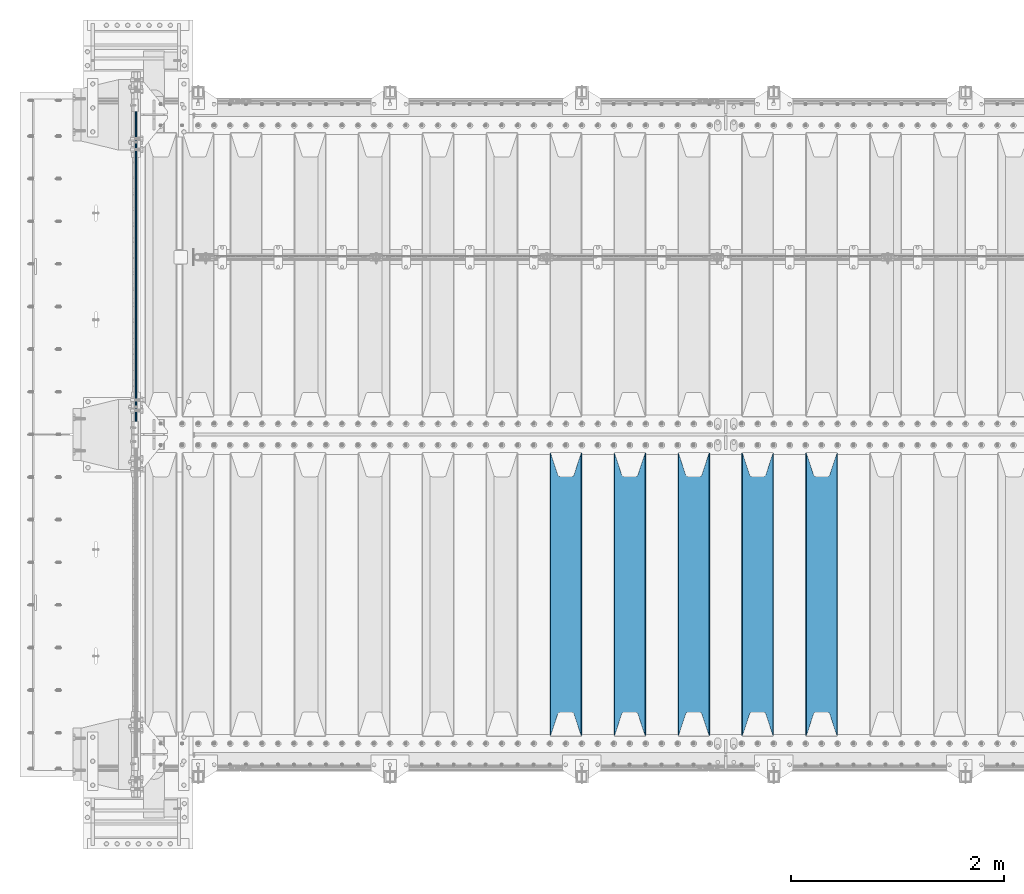
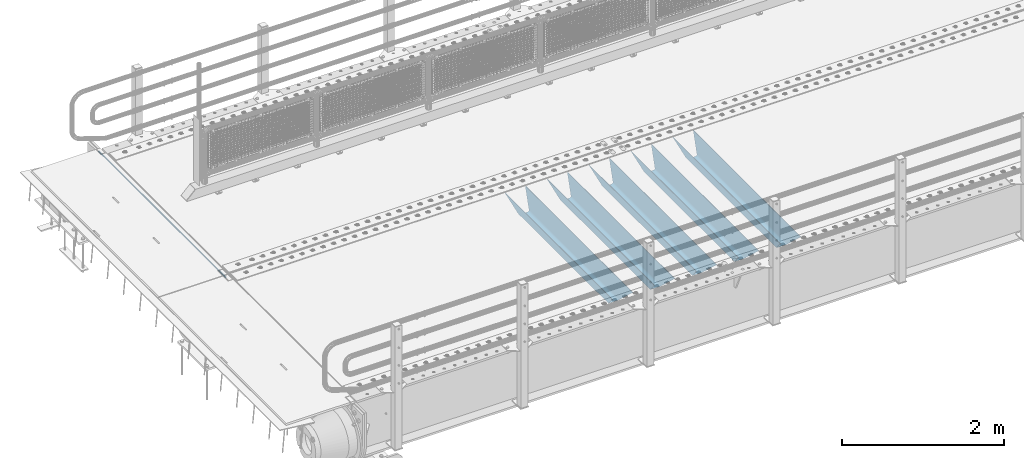
# One storey, part 92 of 208: 6 beams.
"""IFC2X3 building model written with IfcOpenShell, lengths in millimetres."""

import ifcopenshell
import ifcopenshell.guid

model = None  # the IFC model being written
_history = None  # IfcOwnerHistory: only IFC2X3 demands one
_inside = {}  # id of a spatial element -> (the spatial element, [elements in it])
_under = {}  # id of a project, library or spatial element -> (it, [spatial elements below it])
_declared = {}  # id of a project -> (the project, [libraries it declares])
_typed = {}  # id of a type object -> (the type object, [elements of that type])
_made_of = {}  # id of a material, layer set ... -> (it, [elements and type objects made of it])


def new_model(schema):
    """Start an empty IFC model of exactly this schema.

    Asked for "IFC4X3", IfcOpenShell would pick the latest addendum, in which some entities
    have other attributes; the version numbers below select the first issue.
    IFC2X3 requires an IfcOwnerHistory on every rooted entity: one is made here for all.
    """
    global model, _history
    if schema == "IFC4X3":
        model = ifcopenshell.file(schema_version=(4, 3, 0, 0))
    else:
        model = ifcopenshell.file(schema=schema)
    _inside.clear()
    _under.clear()
    _declared.clear()
    _typed.clear()
    _made_of.clear()
    _history = None
    if model.schema == "IFC2X3":
        org = make("IfcOrganization", Name="unknown")
        user = make(
            "IfcPersonAndOrganization",
            ThePerson=make("IfcPerson", FamilyName="unknown"),
            TheOrganization=org,
        )
        app = make(
            "IfcApplication",
            ApplicationDeveloper=org,
            Version="unknown",
            ApplicationFullName="unknown",
            ApplicationIdentifier="unknown",
        )
        _history = make(
            "IfcOwnerHistory",
            OwningUser=user,
            OwningApplication=app,
            ChangeAction="ADDED",
            CreationDate=0,
        )
    return model


def make(cls, **values):
    """One entity of the class cls with the attributes given. An attribute that is None is left unset."""
    return model.create_entity(
        cls, **{name: value for name, value in values.items() if value is not None}
    )


def rooted(cls, **values):
    """An entity with a GlobalId (a new one), such as an element, a storey or a relation."""
    return make(cls, GlobalId=ifcopenshell.guid.new(), OwnerHistory=_history, **values)


def si_unit(unit_type, name, prefix=None):
    """IfcSIUnit, for example si_unit("LENGTHUNIT", "METRE", prefix="MILLI")."""
    return make("IfcSIUnit", UnitType=unit_type, Prefix=prefix, Name=name)


def assignment(units):
    """IfcUnitAssignment: the units of a project."""
    return None if units is None else make("IfcUnitAssignment", Units=units)


def point(xyz):
    """IfcCartesianPoint."""
    return None if xyz is None else make("IfcCartesianPoint", Coordinates=xyz)


def direction(xyz):
    """IfcDirection."""
    return None if xyz is None else make("IfcDirection", DirectionRatios=xyz)


def frame(location, z_axis=None, x_axis=None):
    """IfcAxis2Placement3D, a coordinate frame: its origin and axes. An axis left out is left unset."""
    return make(
        "IfcAxis2Placement3D",
        Location=point(location),
        Axis=direction(z_axis),
        RefDirection=direction(x_axis),
    )


def origin_with_axes():
    """The frame at (0, 0, 0) with the z axis (0, 0, 1) and the x axis (1, 0, 0) written out."""
    return frame((0.0, 0.0, 0.0), z_axis=(0.0, 0.0, 1.0), x_axis=(1.0, 0.0, 0.0))


def place(relative_to, where):
    """IfcLocalPlacement: puts the frame where relative to a parent placement (None: the world)."""
    return make(
        "IfcLocalPlacement", PlacementRelTo=relative_to, RelativePlacement=where
    )


def context(
    kind, dimensions, precision=None, world=None, true_north=None, identifier=None
):
    """IfcGeometricRepresentationContext, for example the 3D "Model" context."""
    return make(
        "IfcGeometricRepresentationContext",
        ContextIdentifier=identifier,
        ContextType=kind,
        CoordinateSpaceDimension=dimensions,
        Precision=precision,
        WorldCoordinateSystem=world,
        TrueNorth=true_north,
    )


def subcontext(parent, identifier, kind, view, scale=None):
    """IfcGeometricRepresentationSubContext, for example "Body" below "Model"."""
    return make(
        "IfcGeometricRepresentationSubContext",
        ContextIdentifier=identifier,
        ContextType=kind,
        ParentContext=parent,
        TargetScale=scale,
        TargetView=view,
    )


def project(units=None, contexts=None):
    """IfcProject with its units and contexts."""
    return rooted(
        "IfcProject",
        Name="project",
        RepresentationContexts=contexts,
        UnitsInContext=assignment(units),
    )


def spatial(cls, under=None, at=None, **own):
    """A site, building, storey or space (cls), placed at a placement, below another one or the project."""
    s = rooted(cls, ObjectPlacement=at, **own)
    if under is not None:
        _under.setdefault(under.id(), (under, []))[1].append(s)
    return s


def faces_of(points, faces, orient=None, outer=None):
    """IfcFace entities. A face is a list of loops; a loop is a list of indices into points, from 0.

    orient and outer hold one flag for each loop. By default every Orientation is true, the
    first loop of a face is its IfcFaceOuterBound and the others are IfcFaceBound.
    """
    made = []
    for i, loops in enumerate(faces):
        bounds = []
        for j, loop in enumerate(loops):
            is_outer = j == 0 if outer is None else outer[i][j]
            bounds.append(
                make(
                    "IfcFaceOuterBound" if is_outer else "IfcFaceBound",
                    Bound=make("IfcPolyLoop", Polygon=[points[k] for k in loop]),
                    Orientation=True if orient is None else orient[i][j],
                )
            )
        made.append(make("IfcFace", Bounds=bounds))
    return made


def faceted_brep(points, faces, orient=None, outer=None, voids=None):
    """IfcFacetedBrep: a solid bounded by flat faces; with voids (closed shells), ...WithVoids."""
    shared = [point(p) for p in points]
    hull = make("IfcClosedShell", CfsFaces=faces_of(shared, faces, orient, outer))
    if voids is None:
        return make("IfcFacetedBrep", Outer=hull)
    return make(
        "IfcFacetedBrepWithVoids",
        Outer=hull,
        Voids=[
            make(cls, CfsFaces=faces_of(shared, fs, o, b)) for cls, fs, o, b in voids
        ],
    )


def shape(context_of_items, identifier, shape_type, items):
    """IfcShapeRepresentation: the items that make up one representation, for example the "Body"."""
    return make(
        "IfcShapeRepresentation",
        ContextOfItems=context_of_items,
        RepresentationIdentifier=identifier,
        RepresentationType=shape_type,
        Items=items,
    )


def material(Name=None, Category=None):
    """IfcMaterial."""
    return make("IfcMaterial", Name=Name, Category=Category)


def made_of(thing, what):
    """Note that an element or type object is made of a material, layer set ...; save() writes the relation."""
    if what is not None:
        _made_of.setdefault(what.id(), (what, []))[1].append(thing)
    return thing


def type_object(cls, material=None, **own):
    """A type object (cls), such as IfcWallType, which elements share."""
    return made_of(rooted(cls, **own), material)


def element(
    cls,
    number,
    at=None,
    inside=None,
    cuts=None,
    type_object=None,
    material=None,
    context=None,
    identifier="Body",
    shape_type=None,
    held_by="IfcProductDefinitionShape",
    body=None,
    shapes=None,
    **own,
):
    """One element of the class cls, such as IfcWall. Its Tag is "e" and its number.

    at: its placement. inside: the storey or other place that contains it. cuts: it is an
    opening in that element (IfcRelVoidsElement). A single representation is given by context,
    identifier, shape_type and body (its items); several are given by shapes. held_by: the class
    of the entity that holds the representations. save() writes the other relations.
    """
    e = rooted(cls, Tag="e%d" % number, ObjectPlacement=at, **own)
    if body is not None:
        shapes = [shape(context, identifier, shape_type, body)]
    if shapes is not None:
        e.Representation = make(held_by, Representations=shapes)
    if inside is not None:
        _inside.setdefault(inside.id(), (inside, []))[1].append(e)
    if cuts is not None:
        rooted(
            "IfcRelVoidsElement", RelatingBuildingElement=cuts, RelatedOpeningElement=e
        )
    if type_object is not None:
        _typed.setdefault(type_object.id(), (type_object, []))[1].append(e)
    return made_of(e, material)


def aggregate(whole, parts):
    """IfcRelAggregates: a whole, such as a stair, and the parts it consists of."""
    return rooted("IfcRelAggregates", RelatingObject=whole, RelatedObjects=parts)


def save(model, path):
    """Write the relations noted so far, then the file.

    IfcRelAggregates (storeys below a building ...), IfcRelContainedInSpatialStructure (elements
    in a storey), IfcRelDefinesByType, IfcRelAssociatesMaterial and IfcRelDeclares: one each for
    every whole, place, type object, material and project.
    """
    for whole, parts in _under.values():
        aggregate(whole, parts)
    for where, things in _inside.values():
        rooted(
            "IfcRelContainedInSpatialStructure",
            RelatedElements=things,
            RelatingStructure=where,
        )
    for kind, things in _typed.values():
        rooted("IfcRelDefinesByType", RelatedObjects=things, RelatingType=kind)
    for what, things in _made_of.values():
        rooted("IfcRelAssociatesMaterial", RelatedObjects=things, RelatingMaterial=what)
    for by, libraries in _declared.values():
        rooted("IfcRelDeclares", RelatingContext=by, RelatedDefinitions=libraries)
    model.write(path)


model = new_model("IFC2X3")

# Units and contexts
model_context = context("Model", 3, precision=1e-05, world=origin_with_axes())
body_context = subcontext(model_context, "Body", "Model", "MODEL_VIEW")
ifc_project = project(units=[si_unit("LENGTHUNIT", "METRE", prefix="MILLI"), si_unit("AREAUNIT", "SQUARE_METRE"), si_unit("VOLUMEUNIT", "CUBIC_METRE"), si_unit("MASSUNIT", "GRAM", prefix="KILO"), si_unit("TIMEUNIT", "SECOND"), si_unit("PLANEANGLEUNIT", "RADIAN"), si_unit("SOLIDANGLEUNIT", "STERADIAN"), si_unit("THERMODYNAMICTEMPERATUREUNIT", "DEGREE_CELSIUS"), si_unit("LUMINOUSINTENSITYUNIT", "LUMEN")], contexts=[model_context])

# Site, building, storey
site_placement = place(None, origin_with_axes())
site = spatial("IfcSite", under=ifc_project, at=site_placement, CompositionType="ELEMENT")
building_placement = place(site_placement, origin_with_axes())
building = spatial("IfcBuilding", under=site, at=building_placement, Name="Standard", CompositionType="ELEMENT")
storey_placement = place(building_placement, origin_with_axes())
storey = spatial("IfcBuildingStorey", under=building, at=storey_placement, Name="Undefined", CompositionType="ELEMENT", Elevation=0.0)

# Beams
ifc_material = material(Name="STEEL/S355N")
beam_type_1 = type_object("IfcBeamType", Name="D20", PredefinedType="NOTDEFINED")
beam_1_placement = place(storey_placement, frame((-42485.0, 3005.0, -25.9999999971316), z_axis=(0.0, 0.0, 1.0), x_axis=(0.0, 1.0, 0.0)))
element("IfcBeam", 1, at=beam_1_placement, inside=storey, type_object=beam_type_1, material=ifc_material, ObjectType="D20", context=body_context, shape_type="Brep", body=[
    faceted_brep([(0.0, -10.0, 0.0), (0.0, -7.07106781186303, -7.07106781186548), (3145.0, -7.07106781186303, -7.07106781186548), (3145.0, -10.0, 0.0), (0.0, 0.0, -10.0), (3145.0, 0.0, -10.0), (0.0, 7.07106781186303, -7.07106781186547), (3145.0, 7.07106781186303, -7.07106781186547), (0.0, 10.0, 0.0), (3145.0, 10.0, 0.0), (0.0, 7.07106781186303, 7.07106781186548), (3145.0, 7.07106781186303, 7.07106781186548), (0.0, 0.0, 10.0), (3145.0, 0.0, 10.0), (0.0, -7.07106781186303, 7.07106781186548), (3145.0, -7.07106781186303, 7.07106781186548)], [[[0, 1, 2, 3]], [[1, 4, 5, 2]], [[4, 6, 7, 5]], [[6, 8, 9, 7]], [[8, 10, 11, 9]], [[10, 12, 13, 11]], [[12, 14, 15, 13]], [[14, 0, 3, 15]], [[5, 7, 9, 11, 13, 15, 3, 2]], [[14, 12, 10, 8, 6, 4, 1, 0]]]),
])
beam_type_2 = type_object("IfcBeamType", PredefinedType="NOTDEFINED")
beam_2_placement = place(storey_placement, frame((-36050.0, 175.0, -115.0), z_axis=(0.0, 0.0, 1.0), x_axis=(0.0, 1.0, 0.0)))
element("IfcBeam", 2, at=beam_2_placement, inside=storey, type_object=beam_type_2, material=ifc_material, context=body_context, shape_type="Brep", body=[
    faceted_brep([(0.0, 150.0, 115.0), (0.0, 143.689999999999, 115.0), (2650.00000000297, 143.689999999999, 115.0), (2650.00000000297, 150.0, 115.0), (2650.00000000297, 142.059565218402, 110.0000000031), (2650.00000000297, 148.369565218403, 110.0000000031), (2441.90079219208, -80.1103600731112, -98.0992078077845), (2437.7588105432, -77.5672621345584, -102.241189456673), (2434.06523489746, -74.4080125315522, -105.934765102404), (2430.91086095089, -70.710272125576, -109.089139048974), (2428.37322971128, -66.5649389910068, -111.626770288588), (2426.51472138055, -62.0739139532889, -113.485278619323), (2425.38102192091, -57.3475956567672, -114.618978078955), (2424.99999999987, -52.5021667386536, -115.0), (2424.99999999987, 52.5021667386536, -115.0), (2425.38102192091, 57.3475956567672, -114.618978078955), (2426.51472138055, 62.0739139532889, -113.485278619323), (2428.37322971128, 66.5649389910068, -111.626770288588), (2430.91086095089, 70.710272125576, -109.089139048974), (2434.06523489746, 74.4080125315522, -105.934765102404), (2437.7588105432, 77.5672621345584, -102.241189456673), (2441.90079219208, 80.1103600731112, -98.0992078077846), (2446.38936140511, 81.9747917625791, -93.6106385947584), (2448.24948500409, 76.2713538057251, -91.7505149957729), (2444.62967112262, 74.76777986261, -95.3703288772456), (2441.28936334126, 72.7168944282894, -98.710636658607), (2438.31067330438, 70.1691124903846, -101.689326695487), (2435.76682334747, 67.1870637758839, -104.233176652398), (2433.72034654133, 63.8440531834895, -106.279653458539), (2432.22154950041, 60.222258798236, -107.778450499454), (2431.30727574265, 56.4107117849089, -108.692724257221), (2430.99999999987, 52.5031078186876, -109.0), (2430.99999999987, -52.5031078186876, -109.0), (2431.30727574265, -56.4107117849089, -108.692724257221), (2432.22154950041, -60.222258798236, -107.778450499454), (2433.72034654133, -63.8440531834895, -106.279653458539), (2435.76682334747, -67.1870637758839, -104.233176652398), (2438.31067330438, -70.1691124903846, -101.689326695487), (2441.28936334126, -72.7168944282894, -98.7106366586071), (2444.62967112262, -74.76777986261, -95.3703288772457), (2448.24948500409, -76.2713538057251, -91.7505149957729), (2650.00000000297, -142.059565218402, 110.0000000031), (2650.00000000297, -148.369565218403, 110.0000000031), (2446.38936140511, -81.9747917625791, -93.6106385947584), (2650.00000000297, -143.689999999999, 115.0), (2650.00000000297, -150.0, 115.0), (0.0, -143.689999999999, 115.0), (0.0, -150.0, 115.0), (0.0, -148.369565218261, 110.000000002663), (203.610638597421, -81.9747917625791, -93.6106385947584), (208.099207810448, -80.1103600731112, -98.0992078077845), (212.241189459336, -77.5672621345584, -102.241189456673), (215.934765105067, -74.4080125315522, -105.934765102404), (219.089139051637, -70.710272125576, -109.089139048974), (221.626770291251, -66.5649389910068, -111.626770288588), (223.485278621986, -62.0739139532889, -113.485278619323), (224.618978081618, -57.3475956567672, -114.618978078955), (225.000000002663, -52.5021667386536, -115.0), (225.000000002663, 52.5021667386536, -115.0), (224.618978081618, 57.3475956567672, -114.618978078955), (223.485278621986, 62.0739139532889, -113.485278619323), (221.626770291251, 66.5649389910068, -111.626770288588), (219.089139051637, 70.710272125576, -109.089139048974), (215.934765105067, 74.4080125315522, -105.934765102404), (212.241189459336, 77.5672621345584, -102.241189456673), (208.099207810448, 80.1103600731112, -98.0992078077846), (203.610638597421, 81.9747917625791, -93.6106385947584), (0.0, 148.369565218261, 110.000000002663), (0.0, 142.05956521826, 110.000000002663), (201.750514998436, 76.2713538057251, -91.7505149957729), (205.370328879908, 74.76777986261, -95.3703288772456), (208.71063666127, 72.7168944282894, -98.710636658607), (211.68932669815, 70.1691124903846, -101.689326695487), (214.233176655061, 67.1870637758839, -104.233176652398), (216.279653461202, 63.8440531834895, -106.279653458539), (217.778450502116, 60.222258798236, -107.778450499454), (218.692724259884, 56.4107117849089, -108.692724257221), (219.000000002663, 52.5031078186876, -109.0), (219.000000002663, -52.5031078186876, -109.0), (218.692724259884, -56.4107117849089, -108.692724257221), (217.778450502116, -60.222258798236, -107.778450499454), (216.279653461202, -63.8440531834895, -106.279653458539), (214.233176655061, -67.1870637758839, -104.233176652398), (211.68932669815, -70.1691124903846, -101.689326695487), (208.71063666127, -72.7168944282894, -98.7106366586071), (205.370328879908, -74.76777986261, -95.3703288772457), (201.750514998436, -76.2713538057251, -91.7505149957729), (0.0, -142.05956521826, 110.000000002663)], [[[0, 1, 2, 3]], [[3, 2, 4, 5]], [[6, 7, 8, 9, 10, 11, 12, 13, 14, 15, 16, 17, 18, 19, 20, 21, 22, 5, 4, 23, 24, 25, 26, 27, 28, 29, 30, 31, 32, 33, 34, 35, 36, 37, 38, 39, 40, 41, 42, 43]], [[44, 45, 42, 41]], [[46, 47, 45, 44]], [[43, 42, 45, 47, 48, 49]], [[6, 43, 49, 50]], [[7, 6, 50, 51]], [[8, 7, 51, 52]], [[9, 8, 52, 53]], [[10, 9, 53, 54]], [[11, 10, 54, 55]], [[12, 11, 55, 56]], [[13, 12, 56, 57]], [[14, 13, 57, 58]], [[15, 14, 58, 59]], [[16, 15, 59, 60]], [[17, 16, 60, 61]], [[18, 17, 61, 62]], [[19, 18, 62, 63]], [[20, 19, 63, 64]], [[21, 20, 64, 65]], [[22, 21, 65, 66]], [[0, 3, 5, 22, 66, 67]], [[1, 0, 67, 68]], [[23, 4, 2, 1, 68, 69]], [[24, 23, 69, 70]], [[25, 24, 70, 71]], [[26, 25, 71, 72]], [[27, 26, 72, 73]], [[28, 27, 73, 74]], [[29, 28, 74, 75]], [[30, 29, 75, 76]], [[31, 30, 76, 77]], [[32, 31, 77, 78]], [[33, 32, 78, 79]], [[34, 33, 79, 80]], [[35, 34, 80, 81]], [[36, 35, 81, 82]], [[37, 36, 82, 83]], [[38, 37, 83, 84]], [[39, 38, 84, 85]], [[40, 39, 85, 86]], [[46, 44, 41, 40, 86, 87]], [[47, 46, 87, 48]], [[86, 85, 84, 83, 82, 81, 80, 79, 78, 77, 76, 75, 74, 73, 72, 71, 70, 69, 68, 67, 66, 65, 64, 63, 62, 61, 60, 59, 58, 57, 56, 55, 54, 53, 52, 51, 50, 49, 48, 87]]]),
])
beam_3_placement = place(storey_placement, frame((-36650.0, 175.0, -115.0), z_axis=(0.0, 0.0, 1.0), x_axis=(0.0, 1.0, 0.0)))
element("IfcBeam", 3, at=beam_3_placement, inside=storey, type_object=beam_type_2, material=ifc_material, context=body_context, shape_type="Brep", body=[
    faceted_brep([(0.0, 150.0, 115.0), (0.0, 143.689999999999, 115.0), (2650.00000000297, 143.689999999999, 115.0), (2650.00000000297, 150.0, 115.0), (2650.00000000297, 142.059565218402, 110.0000000031), (2650.00000000297, 148.369565218403, 110.0000000031), (2441.90079219208, -80.1103600731112, -98.0992078077845), (2437.7588105432, -77.5672621345584, -102.241189456673), (2434.06523489746, -74.4080125315522, -105.934765102404), (2430.91086095089, -70.710272125576, -109.089139048974), (2428.37322971128, -66.5649389910068, -111.626770288588), (2426.51472138055, -62.0739139532889, -113.485278619323), (2425.38102192091, -57.3475956567672, -114.618978078955), (2424.99999999987, -52.5021667386536, -115.0), (2424.99999999987, 52.5021667386536, -115.0), (2425.38102192091, 57.3475956567672, -114.618978078955), (2426.51472138055, 62.0739139532889, -113.485278619323), (2428.37322971128, 66.5649389910068, -111.626770288588), (2430.91086095089, 70.710272125576, -109.089139048974), (2434.06523489746, 74.4080125315522, -105.934765102404), (2437.7588105432, 77.5672621345584, -102.241189456673), (2441.90079219208, 80.1103600731112, -98.0992078077846), (2446.38936140511, 81.9747917625791, -93.6106385947584), (2448.24948500409, 76.2713538057251, -91.7505149957729), (2444.62967112262, 74.76777986261, -95.3703288772456), (2441.28936334126, 72.7168944282894, -98.710636658607), (2438.31067330438, 70.1691124903846, -101.689326695487), (2435.76682334747, 67.1870637758839, -104.233176652398), (2433.72034654133, 63.8440531834895, -106.279653458539), (2432.22154950041, 60.222258798236, -107.778450499454), (2431.30727574265, 56.4107117849089, -108.692724257221), (2430.99999999987, 52.5031078186876, -109.0), (2430.99999999987, -52.5031078186876, -109.0), (2431.30727574265, -56.4107117849089, -108.692724257221), (2432.22154950041, -60.222258798236, -107.778450499454), (2433.72034654133, -63.8440531834895, -106.279653458539), (2435.76682334747, -67.1870637758839, -104.233176652398), (2438.31067330438, -70.1691124903846, -101.689326695487), (2441.28936334126, -72.7168944282894, -98.7106366586071), (2444.62967112262, -74.76777986261, -95.3703288772457), (2448.24948500409, -76.2713538057251, -91.7505149957729), (2650.00000000297, -142.059565218402, 110.0000000031), (2650.00000000297, -148.369565218403, 110.0000000031), (2446.38936140511, -81.9747917625791, -93.6106385947584), (2650.00000000297, -143.689999999999, 115.0), (2650.00000000297, -150.0, 115.0), (0.0, -143.689999999999, 115.0), (0.0, -150.0, 115.0), (0.0, -148.369565218261, 110.000000002663), (203.610638597421, -81.9747917625791, -93.6106385947584), (208.099207810448, -80.1103600731112, -98.0992078077845), (212.241189459336, -77.5672621345584, -102.241189456673), (215.934765105067, -74.4080125315522, -105.934765102404), (219.089139051637, -70.710272125576, -109.089139048974), (221.626770291251, -66.5649389910068, -111.626770288588), (223.485278621986, -62.0739139532889, -113.485278619323), (224.618978081618, -57.3475956567672, -114.618978078955), (225.000000002663, -52.5021667386536, -115.0), (225.000000002663, 52.5021667386536, -115.0), (224.618978081618, 57.3475956567672, -114.618978078955), (223.485278621986, 62.0739139532889, -113.485278619323), (221.626770291251, 66.5649389910068, -111.626770288588), (219.089139051637, 70.710272125576, -109.089139048974), (215.934765105067, 74.4080125315522, -105.934765102404), (212.241189459336, 77.5672621345584, -102.241189456673), (208.099207810448, 80.1103600731112, -98.0992078077846), (203.610638597421, 81.9747917625791, -93.6106385947584), (0.0, 148.369565218261, 110.000000002663), (0.0, 142.05956521826, 110.000000002663), (201.750514998436, 76.2713538057251, -91.7505149957729), (205.370328879908, 74.76777986261, -95.3703288772456), (208.71063666127, 72.7168944282894, -98.710636658607), (211.68932669815, 70.1691124903846, -101.689326695487), (214.233176655061, 67.1870637758839, -104.233176652398), (216.279653461202, 63.8440531834895, -106.279653458539), (217.778450502116, 60.222258798236, -107.778450499454), (218.692724259884, 56.4107117849089, -108.692724257221), (219.000000002663, 52.5031078186876, -109.0), (219.000000002663, -52.5031078186876, -109.0), (218.692724259884, -56.4107117849089, -108.692724257221), (217.778450502116, -60.222258798236, -107.778450499454), (216.279653461202, -63.8440531834895, -106.279653458539), (214.233176655061, -67.1870637758839, -104.233176652398), (211.68932669815, -70.1691124903846, -101.689326695487), (208.71063666127, -72.7168944282894, -98.7106366586071), (205.370328879908, -74.76777986261, -95.3703288772457), (201.750514998436, -76.2713538057251, -91.7505149957729), (0.0, -142.05956521826, 110.000000002663)], [[[0, 1, 2, 3]], [[3, 2, 4, 5]], [[6, 7, 8, 9, 10, 11, 12, 13, 14, 15, 16, 17, 18, 19, 20, 21, 22, 5, 4, 23, 24, 25, 26, 27, 28, 29, 30, 31, 32, 33, 34, 35, 36, 37, 38, 39, 40, 41, 42, 43]], [[44, 45, 42, 41]], [[46, 47, 45, 44]], [[43, 42, 45, 47, 48, 49]], [[6, 43, 49, 50]], [[7, 6, 50, 51]], [[8, 7, 51, 52]], [[9, 8, 52, 53]], [[10, 9, 53, 54]], [[11, 10, 54, 55]], [[12, 11, 55, 56]], [[13, 12, 56, 57]], [[14, 13, 57, 58]], [[15, 14, 58, 59]], [[16, 15, 59, 60]], [[17, 16, 60, 61]], [[18, 17, 61, 62]], [[19, 18, 62, 63]], [[20, 19, 63, 64]], [[21, 20, 64, 65]], [[22, 21, 65, 66]], [[0, 3, 5, 22, 66, 67]], [[1, 0, 67, 68]], [[23, 4, 2, 1, 68, 69]], [[24, 23, 69, 70]], [[25, 24, 70, 71]], [[26, 25, 71, 72]], [[27, 26, 72, 73]], [[28, 27, 73, 74]], [[29, 28, 74, 75]], [[30, 29, 75, 76]], [[31, 30, 76, 77]], [[32, 31, 77, 78]], [[33, 32, 78, 79]], [[34, 33, 79, 80]], [[35, 34, 80, 81]], [[36, 35, 81, 82]], [[37, 36, 82, 83]], [[38, 37, 83, 84]], [[39, 38, 84, 85]], [[40, 39, 85, 86]], [[46, 44, 41, 40, 86, 87]], [[47, 46, 87, 48]], [[86, 85, 84, 83, 82, 81, 80, 79, 78, 77, 76, 75, 74, 73, 72, 71, 70, 69, 68, 67, 66, 65, 64, 63, 62, 61, 60, 59, 58, 57, 56, 55, 54, 53, 52, 51, 50, 49, 48, 87]]]),
])
beam_4_placement = place(storey_placement, frame((-37250.0, 175.0, -115.0), z_axis=(0.0, 0.0, 1.0), x_axis=(0.0, 1.0, 0.0)))
element("IfcBeam", 4, at=beam_4_placement, inside=storey, type_object=beam_type_2, material=ifc_material, context=body_context, shape_type="Brep", body=[
    faceted_brep([(0.0, 150.0, 115.0), (0.0, 143.689999999999, 115.0), (2650.00000000297, 143.689999999999, 115.0), (2650.00000000297, 150.0, 115.0), (2650.00000000297, 142.059565218402, 110.0000000031), (2650.00000000297, 148.369565218403, 110.0000000031), (2441.90079219208, -80.1103600731112, -98.0992078077845), (2437.7588105432, -77.5672621345584, -102.241189456673), (2434.06523489746, -74.4080125315522, -105.934765102404), (2430.91086095089, -70.710272125576, -109.089139048974), (2428.37322971128, -66.5649389910068, -111.626770288588), (2426.51472138055, -62.0739139532889, -113.485278619323), (2425.38102192091, -57.3475956567672, -114.618978078955), (2424.99999999987, -52.5021667386536, -115.0), (2424.99999999987, 52.5021667386536, -115.0), (2425.38102192091, 57.3475956567672, -114.618978078955), (2426.51472138055, 62.0739139532889, -113.485278619323), (2428.37322971128, 66.5649389910068, -111.626770288588), (2430.91086095089, 70.710272125576, -109.089139048974), (2434.06523489746, 74.4080125315522, -105.934765102404), (2437.7588105432, 77.5672621345584, -102.241189456673), (2441.90079219208, 80.1103600731112, -98.0992078077846), (2446.38936140511, 81.9747917625791, -93.6106385947584), (2448.24948500409, 76.2713538057251, -91.7505149957729), (2444.62967112262, 74.76777986261, -95.3703288772456), (2441.28936334126, 72.7168944282894, -98.710636658607), (2438.31067330438, 70.1691124903846, -101.689326695487), (2435.76682334747, 67.1870637758839, -104.233176652398), (2433.72034654133, 63.8440531834895, -106.279653458539), (2432.22154950041, 60.222258798236, -107.778450499454), (2431.30727574265, 56.4107117849089, -108.692724257221), (2430.99999999987, 52.5031078186876, -109.0), (2430.99999999987, -52.5031078186876, -109.0), (2431.30727574265, -56.4107117849089, -108.692724257221), (2432.22154950041, -60.222258798236, -107.778450499454), (2433.72034654133, -63.8440531834895, -106.279653458539), (2435.76682334747, -67.1870637758839, -104.233176652398), (2438.31067330438, -70.1691124903846, -101.689326695487), (2441.28936334126, -72.7168944282894, -98.7106366586071), (2444.62967112262, -74.76777986261, -95.3703288772457), (2448.24948500409, -76.2713538057251, -91.7505149957729), (2650.00000000297, -142.059565218402, 110.0000000031), (2650.00000000297, -148.369565218403, 110.0000000031), (2446.38936140511, -81.9747917625791, -93.6106385947584), (2650.00000000297, -143.689999999999, 115.0), (2650.00000000297, -150.0, 115.0), (0.0, -143.689999999999, 115.0), (0.0, -150.0, 115.0), (0.0, -148.369565218261, 110.000000002663), (203.610638597421, -81.9747917625791, -93.6106385947584), (208.099207810448, -80.1103600731112, -98.0992078077845), (212.241189459336, -77.5672621345584, -102.241189456673), (215.934765105067, -74.4080125315522, -105.934765102404), (219.089139051637, -70.710272125576, -109.089139048974), (221.626770291251, -66.5649389910068, -111.626770288588), (223.485278621986, -62.0739139532889, -113.485278619323), (224.618978081618, -57.3475956567672, -114.618978078955), (225.000000002663, -52.5021667386536, -115.0), (225.000000002663, 52.5021667386536, -115.0), (224.618978081618, 57.3475956567672, -114.618978078955), (223.485278621986, 62.0739139532889, -113.485278619323), (221.626770291251, 66.5649389910068, -111.626770288588), (219.089139051637, 70.710272125576, -109.089139048974), (215.934765105067, 74.4080125315522, -105.934765102404), (212.241189459336, 77.5672621345584, -102.241189456673), (208.099207810448, 80.1103600731112, -98.0992078077846), (203.610638597421, 81.9747917625791, -93.6106385947584), (0.0, 148.369565218261, 110.000000002663), (0.0, 142.05956521826, 110.000000002663), (201.750514998436, 76.2713538057251, -91.7505149957729), (205.370328879908, 74.76777986261, -95.3703288772456), (208.71063666127, 72.7168944282894, -98.710636658607), (211.68932669815, 70.1691124903846, -101.689326695487), (214.233176655061, 67.1870637758839, -104.233176652398), (216.279653461202, 63.8440531834895, -106.279653458539), (217.778450502116, 60.222258798236, -107.778450499454), (218.692724259884, 56.4107117849089, -108.692724257221), (219.000000002663, 52.5031078186876, -109.0), (219.000000002663, -52.5031078186876, -109.0), (218.692724259884, -56.4107117849089, -108.692724257221), (217.778450502116, -60.222258798236, -107.778450499454), (216.279653461202, -63.8440531834895, -106.279653458539), (214.233176655061, -67.1870637758839, -104.233176652398), (211.68932669815, -70.1691124903846, -101.689326695487), (208.71063666127, -72.7168944282894, -98.7106366586071), (205.370328879908, -74.76777986261, -95.3703288772457), (201.750514998436, -76.2713538057251, -91.7505149957729), (0.0, -142.05956521826, 110.000000002663)], [[[0, 1, 2, 3]], [[3, 2, 4, 5]], [[6, 7, 8, 9, 10, 11, 12, 13, 14, 15, 16, 17, 18, 19, 20, 21, 22, 5, 4, 23, 24, 25, 26, 27, 28, 29, 30, 31, 32, 33, 34, 35, 36, 37, 38, 39, 40, 41, 42, 43]], [[44, 45, 42, 41]], [[46, 47, 45, 44]], [[43, 42, 45, 47, 48, 49]], [[6, 43, 49, 50]], [[7, 6, 50, 51]], [[8, 7, 51, 52]], [[9, 8, 52, 53]], [[10, 9, 53, 54]], [[11, 10, 54, 55]], [[12, 11, 55, 56]], [[13, 12, 56, 57]], [[14, 13, 57, 58]], [[15, 14, 58, 59]], [[16, 15, 59, 60]], [[17, 16, 60, 61]], [[18, 17, 61, 62]], [[19, 18, 62, 63]], [[20, 19, 63, 64]], [[21, 20, 64, 65]], [[22, 21, 65, 66]], [[0, 3, 5, 22, 66, 67]], [[1, 0, 67, 68]], [[23, 4, 2, 1, 68, 69]], [[24, 23, 69, 70]], [[25, 24, 70, 71]], [[26, 25, 71, 72]], [[27, 26, 72, 73]], [[28, 27, 73, 74]], [[29, 28, 74, 75]], [[30, 29, 75, 76]], [[31, 30, 76, 77]], [[32, 31, 77, 78]], [[33, 32, 78, 79]], [[34, 33, 79, 80]], [[35, 34, 80, 81]], [[36, 35, 81, 82]], [[37, 36, 82, 83]], [[38, 37, 83, 84]], [[39, 38, 84, 85]], [[40, 39, 85, 86]], [[46, 44, 41, 40, 86, 87]], [[47, 46, 87, 48]], [[86, 85, 84, 83, 82, 81, 80, 79, 78, 77, 76, 75, 74, 73, 72, 71, 70, 69, 68, 67, 66, 65, 64, 63, 62, 61, 60, 59, 58, 57, 56, 55, 54, 53, 52, 51, 50, 49, 48, 87]]]),
])
beam_5_placement = place(storey_placement, frame((-37850.0, 175.0, -115.0), z_axis=(0.0, 0.0, 1.0), x_axis=(0.0, 1.0, 0.0)))
element("IfcBeam", 5, at=beam_5_placement, inside=storey, type_object=beam_type_2, material=ifc_material, context=body_context, shape_type="Brep", body=[
    faceted_brep([(0.0, 150.0, 115.0), (0.0, 143.689999999999, 115.0), (2650.00000000297, 143.689999999999, 115.0), (2650.00000000297, 150.0, 115.0), (2650.00000000297, 142.059565218402, 110.0000000031), (2650.00000000297, 148.369565218403, 110.0000000031), (2441.90079219208, -80.1103600731112, -98.0992078077845), (2437.7588105432, -77.5672621345584, -102.241189456673), (2434.06523489746, -74.4080125315522, -105.934765102404), (2430.91086095089, -70.710272125576, -109.089139048974), (2428.37322971128, -66.5649389910068, -111.626770288588), (2426.51472138055, -62.0739139532889, -113.485278619323), (2425.38102192091, -57.3475956567672, -114.618978078955), (2424.99999999987, -52.5021667386536, -115.0), (2424.99999999987, 52.5021667386536, -115.0), (2425.38102192091, 57.3475956567672, -114.618978078955), (2426.51472138055, 62.0739139532889, -113.485278619323), (2428.37322971128, 66.5649389910068, -111.626770288588), (2430.91086095089, 70.710272125576, -109.089139048974), (2434.06523489746, 74.4080125315522, -105.934765102404), (2437.7588105432, 77.5672621345584, -102.241189456673), (2441.90079219208, 80.1103600731112, -98.0992078077846), (2446.38936140511, 81.9747917625791, -93.6106385947584), (2448.24948500409, 76.2713538057251, -91.7505149957729), (2444.62967112262, 74.76777986261, -95.3703288772456), (2441.28936334126, 72.7168944282894, -98.710636658607), (2438.31067330438, 70.1691124903846, -101.689326695487), (2435.76682334747, 67.1870637758839, -104.233176652398), (2433.72034654133, 63.8440531834895, -106.279653458539), (2432.22154950041, 60.222258798236, -107.778450499454), (2431.30727574265, 56.4107117849089, -108.692724257221), (2430.99999999987, 52.5031078186876, -109.0), (2430.99999999987, -52.5031078186876, -109.0), (2431.30727574265, -56.4107117849089, -108.692724257221), (2432.22154950041, -60.222258798236, -107.778450499454), (2433.72034654133, -63.8440531834895, -106.279653458539), (2435.76682334747, -67.1870637758839, -104.233176652398), (2438.31067330438, -70.1691124903846, -101.689326695487), (2441.28936334126, -72.7168944282894, -98.7106366586071), (2444.62967112262, -74.76777986261, -95.3703288772457), (2448.24948500409, -76.2713538057251, -91.7505149957729), (2650.00000000297, -142.059565218402, 110.0000000031), (2650.00000000297, -148.369565218403, 110.0000000031), (2446.38936140511, -81.9747917625791, -93.6106385947584), (2650.00000000297, -143.689999999999, 115.0), (2650.00000000297, -150.0, 115.0), (0.0, -143.689999999999, 115.0), (0.0, -150.0, 115.0), (0.0, -148.369565218261, 110.000000002663), (203.610638597421, -81.9747917625791, -93.6106385947584), (208.099207810448, -80.1103600731112, -98.0992078077845), (212.241189459336, -77.5672621345584, -102.241189456673), (215.934765105067, -74.4080125315522, -105.934765102404), (219.089139051637, -70.710272125576, -109.089139048974), (221.626770291251, -66.5649389910068, -111.626770288588), (223.485278621986, -62.0739139532889, -113.485278619323), (224.618978081618, -57.3475956567672, -114.618978078955), (225.000000002663, -52.5021667386536, -115.0), (225.000000002663, 52.5021667386536, -115.0), (224.618978081618, 57.3475956567672, -114.618978078955), (223.485278621986, 62.0739139532889, -113.485278619323), (221.626770291251, 66.5649389910068, -111.626770288588), (219.089139051637, 70.710272125576, -109.089139048974), (215.934765105067, 74.4080125315522, -105.934765102404), (212.241189459336, 77.5672621345584, -102.241189456673), (208.099207810448, 80.1103600731112, -98.0992078077846), (203.610638597421, 81.9747917625791, -93.6106385947584), (0.0, 148.369565218261, 110.000000002663), (0.0, 142.05956521826, 110.000000002663), (201.750514998436, 76.2713538057251, -91.7505149957729), (205.370328879908, 74.76777986261, -95.3703288772456), (208.71063666127, 72.7168944282894, -98.710636658607), (211.68932669815, 70.1691124903846, -101.689326695487), (214.233176655061, 67.1870637758839, -104.233176652398), (216.279653461202, 63.8440531834895, -106.279653458539), (217.778450502116, 60.222258798236, -107.778450499454), (218.692724259884, 56.4107117849089, -108.692724257221), (219.000000002663, 52.5031078186876, -109.0), (219.000000002663, -52.5031078186876, -109.0), (218.692724259884, -56.4107117849089, -108.692724257221), (217.778450502116, -60.222258798236, -107.778450499454), (216.279653461202, -63.8440531834895, -106.279653458539), (214.233176655061, -67.1870637758839, -104.233176652398), (211.68932669815, -70.1691124903846, -101.689326695487), (208.71063666127, -72.7168944282894, -98.7106366586071), (205.370328879908, -74.76777986261, -95.3703288772457), (201.750514998436, -76.2713538057251, -91.7505149957729), (0.0, -142.05956521826, 110.000000002663)], [[[0, 1, 2, 3]], [[3, 2, 4, 5]], [[6, 7, 8, 9, 10, 11, 12, 13, 14, 15, 16, 17, 18, 19, 20, 21, 22, 5, 4, 23, 24, 25, 26, 27, 28, 29, 30, 31, 32, 33, 34, 35, 36, 37, 38, 39, 40, 41, 42, 43]], [[44, 45, 42, 41]], [[46, 47, 45, 44]], [[43, 42, 45, 47, 48, 49]], [[6, 43, 49, 50]], [[7, 6, 50, 51]], [[8, 7, 51, 52]], [[9, 8, 52, 53]], [[10, 9, 53, 54]], [[11, 10, 54, 55]], [[12, 11, 55, 56]], [[13, 12, 56, 57]], [[14, 13, 57, 58]], [[15, 14, 58, 59]], [[16, 15, 59, 60]], [[17, 16, 60, 61]], [[18, 17, 61, 62]], [[19, 18, 62, 63]], [[20, 19, 63, 64]], [[21, 20, 64, 65]], [[22, 21, 65, 66]], [[0, 3, 5, 22, 66, 67]], [[1, 0, 67, 68]], [[23, 4, 2, 1, 68, 69]], [[24, 23, 69, 70]], [[25, 24, 70, 71]], [[26, 25, 71, 72]], [[27, 26, 72, 73]], [[28, 27, 73, 74]], [[29, 28, 74, 75]], [[30, 29, 75, 76]], [[31, 30, 76, 77]], [[32, 31, 77, 78]], [[33, 32, 78, 79]], [[34, 33, 79, 80]], [[35, 34, 80, 81]], [[36, 35, 81, 82]], [[37, 36, 82, 83]], [[38, 37, 83, 84]], [[39, 38, 84, 85]], [[40, 39, 85, 86]], [[46, 44, 41, 40, 86, 87]], [[47, 46, 87, 48]], [[86, 85, 84, 83, 82, 81, 80, 79, 78, 77, 76, 75, 74, 73, 72, 71, 70, 69, 68, 67, 66, 65, 64, 63, 62, 61, 60, 59, 58, 57, 56, 55, 54, 53, 52, 51, 50, 49, 48, 87]]]),
])
beam_6_placement = place(storey_placement, frame((-38450.0, 175.0, -115.0), z_axis=(0.0, 0.0, 1.0), x_axis=(0.0, 1.0, 0.0)))
element("IfcBeam", 6, at=beam_6_placement, inside=storey, type_object=beam_type_2, material=ifc_material, context=body_context, shape_type="Brep", body=[
    faceted_brep([(0.0, 150.0, 115.0), (0.0, 143.689999999999, 115.0), (2650.00000000297, 143.689999999999, 115.0), (2650.00000000297, 150.0, 115.0), (2650.00000000297, 142.059565218402, 110.0000000031), (2650.00000000297, 148.369565218403, 110.0000000031), (2441.90079219208, -80.1103600731112, -98.0992078077845), (2437.7588105432, -77.5672621345584, -102.241189456673), (2434.06523489746, -74.4080125315522, -105.934765102404), (2430.91086095089, -70.710272125576, -109.089139048974), (2428.37322971128, -66.5649389910068, -111.626770288588), (2426.51472138055, -62.0739139532889, -113.485278619323), (2425.38102192091, -57.3475956567672, -114.618978078955), (2424.99999999987, -52.5021667386536, -115.0), (2424.99999999987, 52.5021667386536, -115.0), (2425.38102192091, 57.3475956567672, -114.618978078955), (2426.51472138055, 62.0739139532889, -113.485278619323), (2428.37322971128, 66.5649389910068, -111.626770288588), (2430.91086095089, 70.710272125576, -109.089139048974), (2434.06523489746, 74.4080125315522, -105.934765102404), (2437.7588105432, 77.5672621345584, -102.241189456673), (2441.90079219208, 80.1103600731112, -98.0992078077846), (2446.38936140511, 81.9747917625791, -93.6106385947584), (2448.24948500409, 76.2713538057251, -91.7505149957729), (2444.62967112262, 74.76777986261, -95.3703288772456), (2441.28936334126, 72.7168944282894, -98.710636658607), (2438.31067330438, 70.1691124903846, -101.689326695487), (2435.76682334747, 67.1870637758839, -104.233176652398), (2433.72034654133, 63.8440531834895, -106.279653458539), (2432.22154950041, 60.222258798236, -107.778450499454), (2431.30727574265, 56.4107117849089, -108.692724257221), (2430.99999999987, 52.5031078186876, -109.0), (2430.99999999987, -52.5031078186876, -109.0), (2431.30727574265, -56.4107117849089, -108.692724257221), (2432.22154950041, -60.222258798236, -107.778450499454), (2433.72034654133, -63.8440531834895, -106.279653458539), (2435.76682334747, -67.1870637758839, -104.233176652398), (2438.31067330438, -70.1691124903846, -101.689326695487), (2441.28936334126, -72.7168944282894, -98.7106366586071), (2444.62967112262, -74.76777986261, -95.3703288772457), (2448.24948500409, -76.2713538057251, -91.7505149957729), (2650.00000000297, -142.059565218402, 110.0000000031), (2650.00000000297, -148.369565218403, 110.0000000031), (2446.38936140511, -81.9747917625791, -93.6106385947584), (2650.00000000297, -143.689999999999, 115.0), (2650.00000000297, -150.0, 115.0), (0.0, -143.689999999999, 115.0), (0.0, -150.0, 115.0), (0.0, -148.369565218261, 110.000000002663), (203.610638597421, -81.9747917625791, -93.6106385947584), (208.099207810448, -80.1103600731112, -98.0992078077845), (212.241189459336, -77.5672621345584, -102.241189456673), (215.934765105067, -74.4080125315522, -105.934765102404), (219.089139051637, -70.710272125576, -109.089139048974), (221.626770291251, -66.5649389910068, -111.626770288588), (223.485278621986, -62.0739139532889, -113.485278619323), (224.618978081618, -57.3475956567672, -114.618978078955), (225.000000002663, -52.5021667386536, -115.0), (225.000000002663, 52.5021667386536, -115.0), (224.618978081618, 57.3475956567672, -114.618978078955), (223.485278621986, 62.0739139532889, -113.485278619323), (221.626770291251, 66.5649389910068, -111.626770288588), (219.089139051637, 70.710272125576, -109.089139048974), (215.934765105067, 74.4080125315522, -105.934765102404), (212.241189459336, 77.5672621345584, -102.241189456673), (208.099207810448, 80.1103600731112, -98.0992078077846), (203.610638597421, 81.9747917625791, -93.6106385947584), (0.0, 148.369565218261, 110.000000002663), (0.0, 142.05956521826, 110.000000002663), (201.750514998436, 76.2713538057251, -91.7505149957729), (205.370328879908, 74.76777986261, -95.3703288772456), (208.71063666127, 72.7168944282894, -98.710636658607), (211.68932669815, 70.1691124903846, -101.689326695487), (214.233176655061, 67.1870637758839, -104.233176652398), (216.279653461202, 63.8440531834895, -106.279653458539), (217.778450502116, 60.222258798236, -107.778450499454), (218.692724259884, 56.4107117849089, -108.692724257221), (219.000000002663, 52.5031078186876, -109.0), (219.000000002663, -52.5031078186876, -109.0), (218.692724259884, -56.4107117849089, -108.692724257221), (217.778450502116, -60.222258798236, -107.778450499454), (216.279653461202, -63.8440531834895, -106.279653458539), (214.233176655061, -67.1870637758839, -104.233176652398), (211.68932669815, -70.1691124903846, -101.689326695487), (208.71063666127, -72.7168944282894, -98.7106366586071), (205.370328879908, -74.76777986261, -95.3703288772457), (201.750514998436, -76.2713538057251, -91.7505149957729), (0.0, -142.05956521826, 110.000000002663)], [[[0, 1, 2, 3]], [[3, 2, 4, 5]], [[6, 7, 8, 9, 10, 11, 12, 13, 14, 15, 16, 17, 18, 19, 20, 21, 22, 5, 4, 23, 24, 25, 26, 27, 28, 29, 30, 31, 32, 33, 34, 35, 36, 37, 38, 39, 40, 41, 42, 43]], [[44, 45, 42, 41]], [[46, 47, 45, 44]], [[43, 42, 45, 47, 48, 49]], [[6, 43, 49, 50]], [[7, 6, 50, 51]], [[8, 7, 51, 52]], [[9, 8, 52, 53]], [[10, 9, 53, 54]], [[11, 10, 54, 55]], [[12, 11, 55, 56]], [[13, 12, 56, 57]], [[14, 13, 57, 58]], [[15, 14, 58, 59]], [[16, 15, 59, 60]], [[17, 16, 60, 61]], [[18, 17, 61, 62]], [[19, 18, 62, 63]], [[20, 19, 63, 64]], [[21, 20, 64, 65]], [[22, 21, 65, 66]], [[0, 3, 5, 22, 66, 67]], [[1, 0, 67, 68]], [[23, 4, 2, 1, 68, 69]], [[24, 23, 69, 70]], [[25, 24, 70, 71]], [[26, 25, 71, 72]], [[27, 26, 72, 73]], [[28, 27, 73, 74]], [[29, 28, 74, 75]], [[30, 29, 75, 76]], [[31, 30, 76, 77]], [[32, 31, 77, 78]], [[33, 32, 78, 79]], [[34, 33, 79, 80]], [[35, 34, 80, 81]], [[36, 35, 81, 82]], [[37, 36, 82, 83]], [[38, 37, 83, 84]], [[39, 38, 84, 85]], [[40, 39, 85, 86]], [[46, 44, 41, 40, 86, 87]], [[47, 46, 87, 48]], [[86, 85, 84, 83, 82, 81, 80, 79, 78, 77, 76, 75, 74, 73, 72, 71, 70, 69, 68, 67, 66, 65, 64, 63, 62, 61, 60, 59, 58, 57, 56, 55, 54, 53, 52, 51, 50, 49, 48, 87]]]),
])

save(model, "model.ifc")
